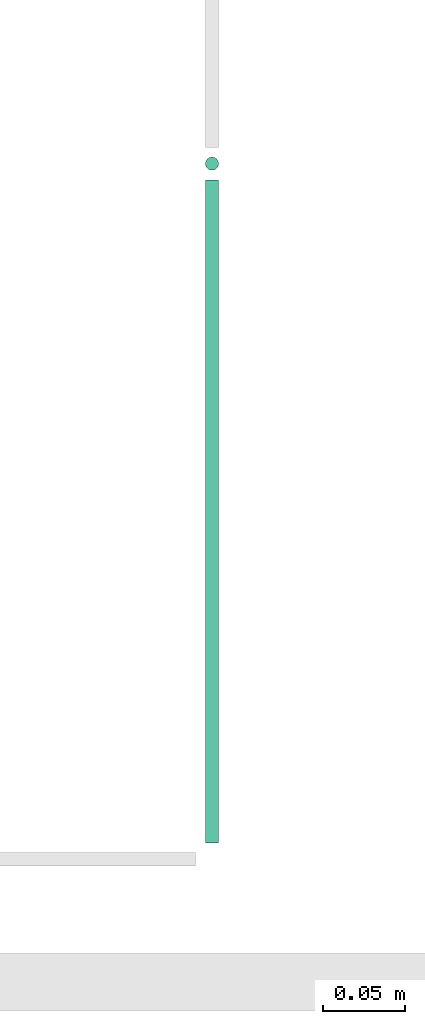
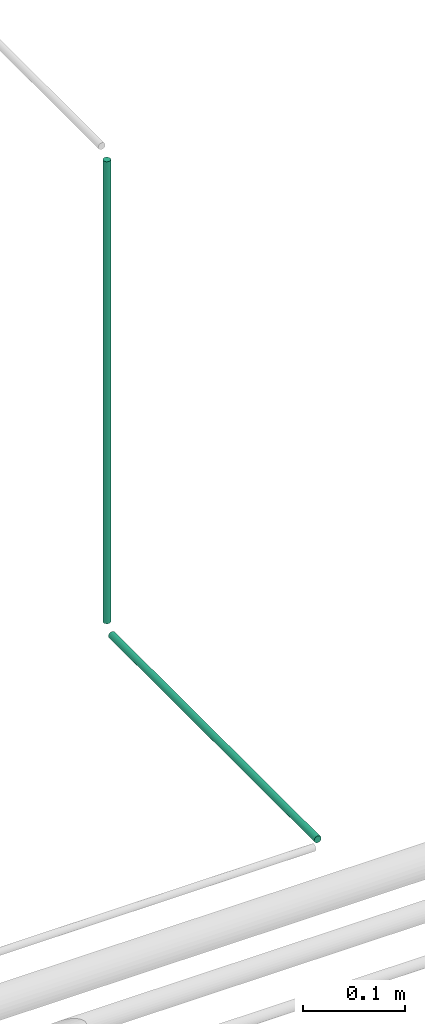
# One storey, part 238 of 331: 2 flow segments.
"""IFC2X3 building model written with IfcOpenShell, lengths in millimetres."""

from ifc_helpers import new_model, entity, si_unit, converted_unit, derived_unit, direction, frame, frame_2d, origin, origin_2d_with_axis, place, context, subcontext, project, spatial, circle, extrude, type_object, element, save


model = new_model("IFC2X3")

# Units and contexts
model_context = context("Model", 3, precision=0.01, world=origin(), true_north=direction((6.12303176911189e-17, 1.0)))
body_context = subcontext(model_context, "Body", "Model", "MODEL_VIEW")
ifc_project = project(units=[si_unit("LENGTHUNIT", "METRE", prefix="MILLI"), si_unit("AREAUNIT", "SQUARE_METRE"), si_unit("VOLUMEUNIT", "CUBIC_METRE"), converted_unit("PLANEANGLEUNIT", "DEGREE", entity("IfcRatioMeasure", 0.0174532925199433), si_unit("PLANEANGLEUNIT", "RADIAN"), dimensions=[0, 0, 0, 0, 0, 0, 0]), si_unit("MASSUNIT", "GRAM", prefix="KILO"), derived_unit("MASSDENSITYUNIT", [(si_unit("MASSUNIT", "GRAM", prefix="KILO"), 1), (si_unit("LENGTHUNIT", "METRE"), -3)]), derived_unit("MOMENTOFINERTIAUNIT", [(si_unit("LENGTHUNIT", "METRE"), 4)]), si_unit("TIMEUNIT", "SECOND"), si_unit("FREQUENCYUNIT", "HERTZ"), si_unit("THERMODYNAMICTEMPERATUREUNIT", "DEGREE_CELSIUS"), derived_unit("THERMALTRANSMITTANCEUNIT", [(si_unit("MASSUNIT", "GRAM", prefix="KILO"), 1), (si_unit("THERMODYNAMICTEMPERATUREUNIT", "KELVIN"), -1), (si_unit("TIMEUNIT", "SECOND"), -3)]), derived_unit("VOLUMETRICFLOWRATEUNIT", [(si_unit("LENGTHUNIT", "METRE"), 3), (si_unit("TIMEUNIT", "SECOND"), -1)]), derived_unit("MASSFLOWRATEUNIT", [(si_unit("MASSUNIT", "GRAM", prefix="KILO"), 1), (si_unit("TIMEUNIT", "SECOND"), -1)]), derived_unit("ROTATIONALFREQUENCYUNIT", [(si_unit("TIMEUNIT", "SECOND"), -1)]), si_unit("ELECTRICCURRENTUNIT", "AMPERE"), si_unit("ELECTRICVOLTAGEUNIT", "VOLT"), si_unit("POWERUNIT", "WATT"), si_unit("FORCEUNIT", "NEWTON", prefix="KILO"), si_unit("ILLUMINANCEUNIT", "LUX"), si_unit("LUMINOUSFLUXUNIT", "LUMEN"), si_unit("LUMINOUSINTENSITYUNIT", "CANDELA"), derived_unit("USERDEFINED", [(si_unit("MASSUNIT", "GRAM", prefix="KILO"), -1), (si_unit("LENGTHUNIT", "METRE"), -2), (si_unit("TIMEUNIT", "SECOND"), 3), (si_unit("LUMINOUSFLUXUNIT", "LUMEN"), 1)]), derived_unit("LINEARVELOCITYUNIT", [(si_unit("LENGTHUNIT", "METRE"), 1), (si_unit("TIMEUNIT", "SECOND"), -1)]), si_unit("PRESSUREUNIT", "PASCAL"), derived_unit("USERDEFINED", [(si_unit("LENGTHUNIT", "METRE"), -2), (si_unit("MASSUNIT", "GRAM", prefix="KILO"), 1), (si_unit("TIMEUNIT", "SECOND"), -2)]), derived_unit("LINEARFORCEUNIT", [(si_unit("MASSUNIT", "GRAM", prefix="KILO"), 1), (si_unit("LENGTHUNIT", "METRE"), 1), (si_unit("TIMEUNIT", "SECOND"), -2), (si_unit("LENGTHUNIT", "METRE"), -1)]), derived_unit("PLANARFORCEUNIT", [(si_unit("MASSUNIT", "GRAM", prefix="KILO"), 1), (si_unit("LENGTHUNIT", "METRE"), 1), (si_unit("TIMEUNIT", "SECOND"), -2), (si_unit("LENGTHUNIT", "METRE"), -2)])], contexts=[model_context])

# Site, building, storey
site_placement = place(None, frame((0.0, -0.00077364408347762, 0.0)))
site = spatial("IfcSite", under=ifc_project, at=site_placement, CompositionType="ELEMENT")
building_placement = place(site_placement, origin())
building = spatial("IfcBuilding", under=site, at=building_placement, CompositionType="ELEMENT")
storey_placement = place(building_placement, origin())
storey = spatial("IfcBuildingStorey", under=building, at=storey_placement, CompositionType="ELEMENT", Elevation=0.0)

# Flow segments
pipe_segment_type = type_object("IfcPipeSegmentType", PredefinedType="NOTDEFINED")
flow_segment_1_placement = place(storey_placement, frame((47040.0665845049, 15909.9846702028, 6669.40472776408)))
element("IfcFlowSegment", 1, at=flow_segment_1_placement, inside=storey, type_object=pipe_segment_type, context=body_context, shape_type="SweptSolid", body=[
    extrude(circle(Radius=4.0, at=frame_2d((0.0, -1.08286712929839e-12), x_axis=(1.0, 0.0))), frame((5.59527223592365, 0.0, 5.59527223591499), z_axis=(0.0, 1.0, 0.0), x_axis=(1.0, 0.0, 0.0)), (0.0, 0.0, 1.0), 405.000000000034),
])
flow_segment_2_placement = place(storey_placement, frame((47040.0665845049, 16319.3893979669, 6685.0)))
element("IfcFlowSegment", 2, at=flow_segment_2_placement, inside=storey, type_object=pipe_segment_type, context=body_context, shape_type="SweptSolid", body=[
    extrude(circle(Radius=4.0, at=origin_2d_with_axis()), frame((5.59527223591499, 5.59527223591499, 0.0)), (0.0, 0.0, 1.0), 555.000000000033),
])

save(model, "model.ifc")
